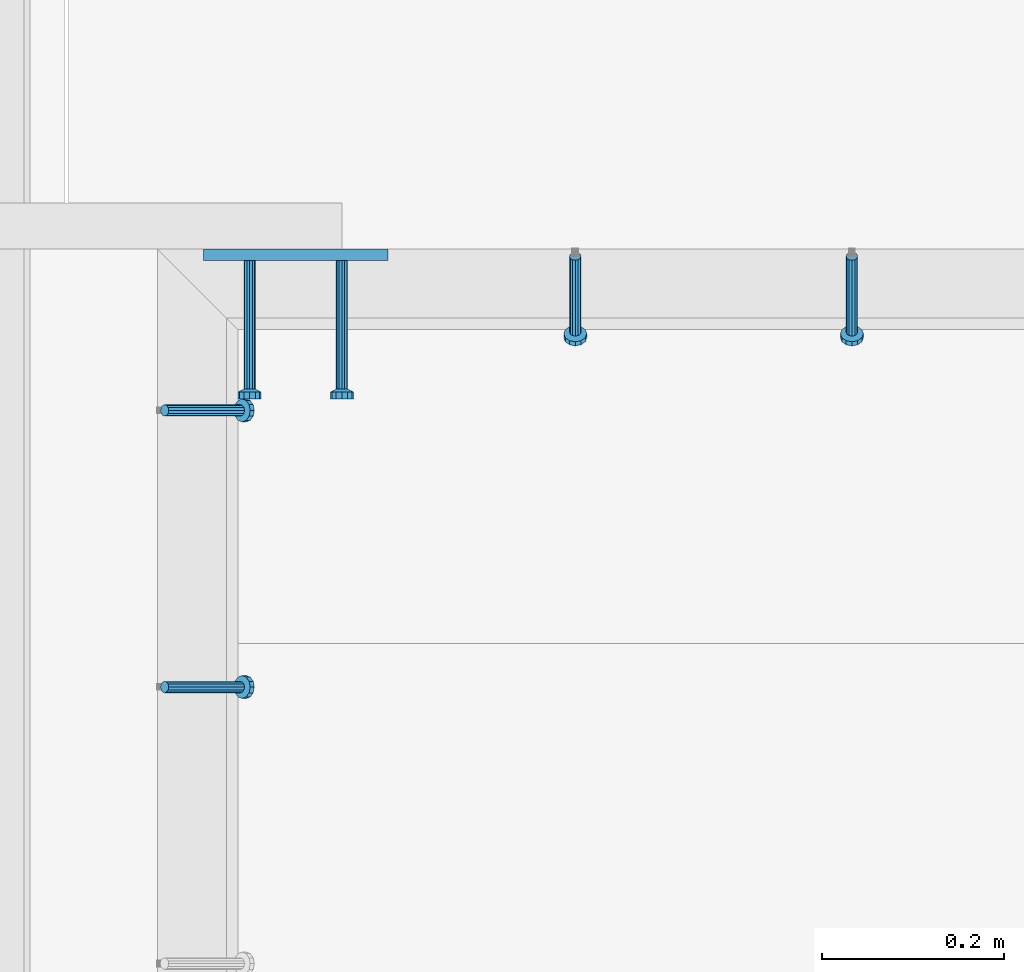
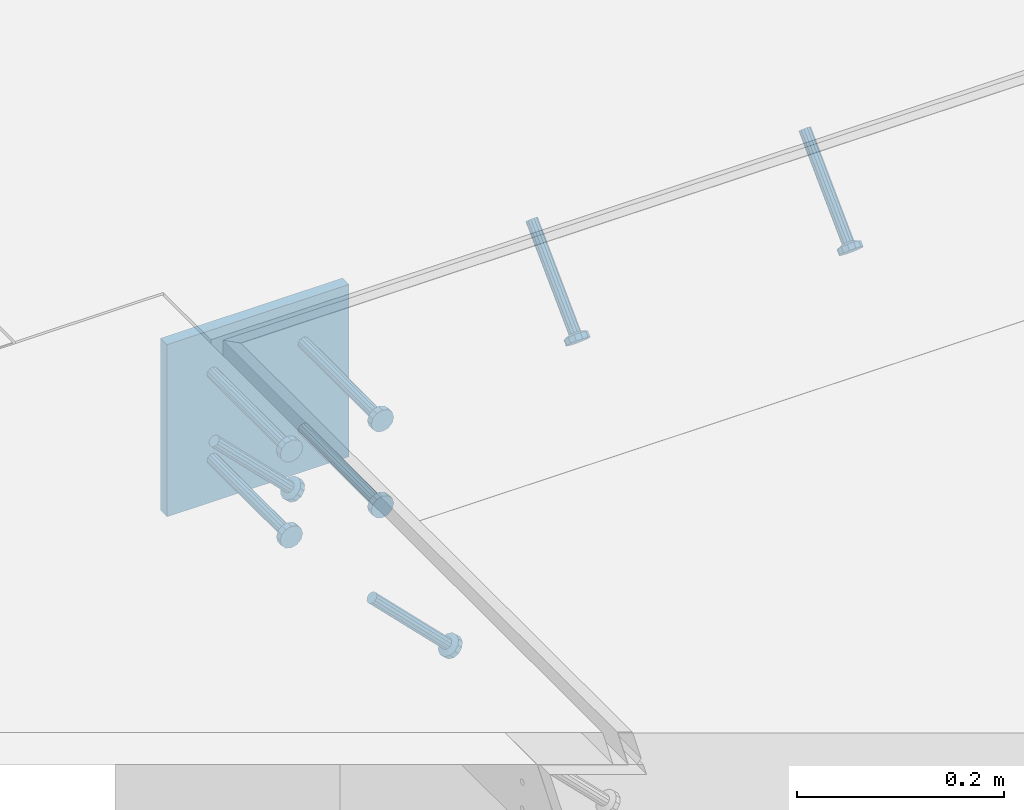
# One storey, part 2537 of 3843: 5 beams, 4 members, 3 elements without a shape of their own.
"""IFC2X3 building model written with IfcOpenShell, lengths in millimetres."""

from ifc_helpers import new_model, si_unit, frame, origin_with_axes, place, context, subcontext, project, spatial, faceted_brep, material, type_object, element, aggregate, save


model = new_model("IFC2X3")

# Units and contexts
model_context = context("Model", 3, precision=1e-05, world=origin_with_axes())
body_context = subcontext(model_context, "Body", "Model", "MODEL_VIEW")
ifc_project = project(units=[si_unit("LENGTHUNIT", "METRE", prefix="MILLI"), si_unit("AREAUNIT", "SQUARE_METRE"), si_unit("VOLUMEUNIT", "CUBIC_METRE"), si_unit("MASSUNIT", "GRAM", prefix="KILO"), si_unit("TIMEUNIT", "SECOND"), si_unit("PLANEANGLEUNIT", "RADIAN"), si_unit("SOLIDANGLEUNIT", "STERADIAN"), si_unit("THERMODYNAMICTEMPERATUREUNIT", "DEGREE_CELSIUS"), si_unit("LUMINOUSINTENSITYUNIT", "LUMEN")], contexts=[model_context])

# Site, building, storey
site_placement = place(None, origin_with_axes())
site = spatial("IfcSite", under=ifc_project, at=site_placement, CompositionType="ELEMENT")
building_placement = place(site_placement, origin_with_axes())
building = spatial("IfcBuilding", under=site, at=building_placement, Name="Undefined", CompositionType="ELEMENT")
storey_placement = place(building_placement, origin_with_axes())
storey = spatial("IfcBuildingStorey", under=building, at=storey_placement, Name="Undefined", CompositionType="ELEMENT", Elevation=0.0)

# Assembly, members
assembly_1_placement = place(storey_placement, origin_with_axes())
assembly_1 = element("IfcElementAssembly", 1, at=assembly_1_placement, inside=storey, Name="EMBED_ANGLE", AssemblyPlace="NOTDEFINED", PredefinedType="RIGID_FRAME")
ifc_material_1 = material(Name="STEEL/A108")
member_type = type_object("IfcMemberType", PredefinedType="NOTDEFINED")
member_1_placement = place(assembly_1_placement, frame((67434.600304105, 90041.2848828318, 30446.6625), z_axis=(-1.0, 0.0, 0.0), x_axis=(0.0, -0.707106781186548, -0.707106781186548)))
member_1 = element("IfcMember", 2, at=member_1_placement, type_object=member_type, material=ifc_material_1, Name="HEADED STUD ANCHOR", context=body_context, shape_type="Brep", body=[
    faceted_brep([(7.27595761418343e-12, -3.18000006675175, 5.5), (0.0, -5.49999999998363, 3.1800000667572), (118.110000000976, -5.49999999999091, 3.1800000667572), (118.110000000983, -3.18000006675175, 5.5), (0.0, -6.3499999046162, 0.0), (118.110000000968, -6.34999990461256, 0.0), (0.0, -5.49999999998363, -3.1800000667572), (118.110000000976, -5.49999999999091, -3.1800000667572), (7.27595761418343e-12, -3.18000006675175, -5.5), (118.110000000983, -3.18000006675175, -5.5), (7.27595761418343e-12, -1.81898940354586e-12, -6.34999990463257), (118.110000000968, -1.81898940354586e-12, -6.34999990463257), (0.0, 3.18000006675175, -5.5), (118.110000000968, 3.18000006674811, -5.5), (7.27595761418343e-12, 5.49999999998363, -3.1800000667572), (118.110000000983, 5.49999999998363, -3.1800000667572), (7.27595761418343e-12, 6.3499999046162, 0.0), (118.110000000976, 6.34999990461256, 0.0), (7.27595761418343e-12, 5.49999999998363, 3.1800000667572), (118.110000000983, 5.49999999998363, 3.1800000667572), (0.0, 3.18000006675175, 5.5), (118.110000000968, 3.18000006674811, 5.5), (7.27595761418343e-12, -1.81898940354586e-12, 6.34999990463257), (118.110000000968, -1.81898940354586e-12, 6.34999990463257), (120.650000000991, -10.9899997710909, 6.34999990463257), (120.650000000998, -6.34000015257152, 10.9899997711182), (120.650000000991, -12.6999998092379, 0.0), (120.650000000991, -10.9899997710909, -6.34999990463257), (120.650000000998, -6.34000015257152, -10.9899997711182), (120.650000000991, -1.81898940354586e-12, -12.6899995803833), (120.650000000991, 6.34000015257152, -10.9899997711182), (120.650000000998, 10.9899997710909, -6.34999990463257), (120.650000000991, 12.6999998092342, 0.0), (120.650000000998, 10.9899997710909, 6.34999990463257), (120.650000000991, 6.34000015257152, 10.9899997711182), (120.650000000991, -1.81898940354586e-12, 12.6899995803833), (127.000000001048, -10.9899997710945, 6.34999990463257), (127.000000001048, -6.34000015257152, 10.9899997711182), (127.000000001048, -12.6999998092342, 0.0), (127.000000001048, -10.9899997710945, -6.34999990463257), (127.000000001048, -6.34000015257152, -10.9899997711182), (127.000000001048, 1.81898940354586e-12, -12.6899995803833), (127.000000001048, 6.34000015256788, -10.9899997711182), (127.000000001048, 10.9899997710909, -6.34999990463257), (127.000000001048, 12.6999998092379, 0.0), (127.000000001048, 10.9899997710909, 6.34999990463257), (127.000000001048, 6.34000015256788, 10.9899997711182), (127.000000001048, 1.81898940354586e-12, 12.6899995803833)], [[[0, 1, 2, 3]], [[1, 4, 5, 2]], [[4, 6, 7, 5]], [[6, 8, 9, 7]], [[8, 10, 11, 9]], [[10, 12, 13, 11]], [[12, 14, 15, 13]], [[14, 16, 17, 15]], [[16, 18, 19, 17]], [[18, 20, 21, 19]], [[20, 22, 23, 21]], [[22, 0, 3, 23]], [[22, 20, 18, 16, 14, 12, 10, 8, 6, 4, 1, 0]], [[3, 2, 24, 25]], [[2, 5, 26, 24]], [[5, 7, 27, 26]], [[7, 9, 28, 27]], [[9, 11, 29, 28]], [[11, 13, 30, 29]], [[13, 15, 31, 30]], [[15, 17, 32, 31]], [[17, 19, 33, 32]], [[19, 21, 34, 33]], [[21, 23, 35, 34]], [[23, 3, 25, 35]], [[25, 24, 36, 37]], [[24, 26, 38, 36]], [[26, 27, 39, 38]], [[27, 28, 40, 39]], [[28, 29, 41, 40]], [[29, 30, 42, 41]], [[30, 31, 43, 42]], [[31, 32, 44, 43]], [[32, 33, 45, 44]], [[33, 34, 46, 45]], [[34, 35, 47, 46]], [[35, 25, 37, 47]], [[38, 39, 40, 41, 42, 43, 44, 45, 46, 47, 37, 36]]]),
])
member_2_placement = place(assembly_1_placement, frame((67129.800304105, 90041.2848828318, 30446.6625), z_axis=(-1.0, 0.0, 0.0), x_axis=(0.0, -0.707106781186548, -0.707106781186548)))
member_2 = element("IfcMember", 3, at=member_2_placement, type_object=member_type, material=ifc_material_1, Name="HEADED STUD ANCHOR", context=body_context, shape_type="Brep", body=[
    faceted_brep([(7.27595761418343e-12, -3.18000006675175, 5.5), (0.0, -5.49999999998363, 3.1800000667572), (118.110000000976, -5.49999999999091, 3.1800000667572), (118.110000000983, -3.18000006675175, 5.5), (0.0, -6.3499999046162, 0.0), (118.110000000968, -6.34999990461256, 0.0), (0.0, -5.49999999998363, -3.1800000667572), (118.110000000976, -5.49999999999091, -3.1800000667572), (7.27595761418343e-12, -3.18000006675175, -5.5), (118.110000000983, -3.18000006675175, -5.5), (7.27595761418343e-12, -1.81898940354586e-12, -6.34999990463257), (118.110000000968, -1.81898940354586e-12, -6.34999990463257), (0.0, 3.18000006675175, -5.5), (118.110000000968, 3.18000006674811, -5.5), (7.27595761418343e-12, 5.49999999998363, -3.1800000667572), (118.110000000983, 5.49999999998363, -3.1800000667572), (7.27595761418343e-12, 6.3499999046162, 0.0), (118.110000000976, 6.34999990461256, 0.0), (7.27595761418343e-12, 5.49999999998363, 3.1800000667572), (118.110000000983, 5.49999999998363, 3.1800000667572), (0.0, 3.18000006675175, 5.5), (118.110000000968, 3.18000006674811, 5.5), (7.27595761418343e-12, -1.81898940354586e-12, 6.34999990463257), (118.110000000968, -1.81898940354586e-12, 6.34999990463257), (120.650000000991, -10.9899997710909, 6.34999990463257), (120.650000000998, -6.34000015257152, 10.9899997711182), (120.650000000991, -12.6999998092379, 0.0), (120.650000000991, -10.9899997710909, -6.34999990463257), (120.650000000998, -6.34000015257152, -10.9899997711182), (120.650000000991, -1.81898940354586e-12, -12.6899995803833), (120.650000000991, 6.34000015257152, -10.9899997711182), (120.650000000998, 10.9899997710909, -6.34999990463257), (120.650000000991, 12.6999998092342, 0.0), (120.650000000998, 10.9899997710909, 6.34999990463257), (120.650000000991, 6.34000015257152, 10.9899997711182), (120.650000000991, -1.81898940354586e-12, 12.6899995803833), (127.000000001048, -10.9899997710945, 6.34999990463257), (127.000000001048, -6.34000015257152, 10.9899997711182), (127.000000001048, -12.6999998092342, 0.0), (127.000000001048, -10.9899997710945, -6.34999990463257), (127.000000001048, -6.34000015257152, -10.9899997711182), (127.000000001048, 1.81898940354586e-12, -12.6899995803833), (127.000000001048, 6.34000015256788, -10.9899997711182), (127.000000001048, 10.9899997710909, -6.34999990463257), (127.000000001048, 12.6999998092379, 0.0), (127.000000001048, 10.9899997710909, 6.34999990463257), (127.000000001048, 6.34000015256788, 10.9899997711182), (127.000000001048, 1.81898940354586e-12, 12.6899995803833)], [[[0, 1, 2, 3]], [[1, 4, 5, 2]], [[4, 6, 7, 5]], [[6, 8, 9, 7]], [[8, 10, 11, 9]], [[10, 12, 13, 11]], [[12, 14, 15, 13]], [[14, 16, 17, 15]], [[16, 18, 19, 17]], [[18, 20, 21, 19]], [[20, 22, 23, 21]], [[22, 0, 3, 23]], [[22, 20, 18, 16, 14, 12, 10, 8, 6, 4, 1, 0]], [[3, 2, 24, 25]], [[2, 5, 26, 24]], [[5, 7, 27, 26]], [[7, 9, 28, 27]], [[9, 11, 29, 28]], [[11, 13, 30, 29]], [[13, 15, 31, 30]], [[15, 17, 32, 31]], [[17, 19, 33, 32]], [[19, 21, 34, 33]], [[21, 23, 35, 34]], [[23, 3, 25, 35]], [[25, 24, 36, 37]], [[24, 26, 38, 36]], [[26, 27, 39, 38]], [[27, 28, 40, 39]], [[28, 29, 41, 40]], [[29, 30, 42, 41]], [[30, 31, 43, 42]], [[31, 32, 44, 43]], [[32, 33, 45, 44]], [[33, 34, 46, 45]], [[34, 35, 47, 46]], [[35, 25, 37, 47]], [[38, 39, 40, 41, 42, 43, 44, 45, 46, 47, 37, 36]]]),
])
aggregate(assembly_1, [member_1, member_2])

assembly_2_placement = place(storey_placement, origin_with_axes())
assembly_2 = element("IfcElementAssembly", 4, at=assembly_2_placement, inside=storey, Name="EMBED_ANGLE", AssemblyPlace="NOTDEFINED", PredefinedType="RIGID_FRAME")
member_3_placement = place(assembly_2_placement, frame((66677.3495, 89566.6227092285, 30446.6625), z_axis=(0.0, 1.0, 0.0), x_axis=(0.707106781186548, 0.0, -0.707106781186548)))
member_3 = element("IfcMember", 5, at=member_3_placement, type_object=member_type, material=ifc_material_1, Name="HEADED STUD ANCHOR", context=body_context, shape_type="Brep", body=[
    faceted_brep([(7.27595761418343e-12, -3.18000006675175, 5.5), (0.0, -5.49999999998363, 3.1800000667572), (118.110000000976, -5.49999999999091, 3.1800000667572), (118.110000000983, -3.18000006675175, 5.5), (0.0, -6.3499999046162, 0.0), (118.110000000968, -6.34999990461256, 0.0), (0.0, -5.49999999998363, -3.1800000667572), (118.110000000976, -5.49999999999091, -3.1800000667572), (7.27595761418343e-12, -3.18000006675175, -5.5), (118.110000000983, -3.18000006675175, -5.5), (7.27595761418343e-12, -1.81898940354586e-12, -6.34999990463257), (118.110000000968, -1.81898940354586e-12, -6.34999990463257), (0.0, 3.18000006675175, -5.5), (118.110000000968, 3.18000006674811, -5.5), (7.27595761418343e-12, 5.49999999998363, -3.1800000667572), (118.110000000983, 5.49999999998363, -3.1800000667572), (7.27595761418343e-12, 6.3499999046162, 0.0), (118.110000000976, 6.34999990461256, 0.0), (7.27595761418343e-12, 5.49999999998363, 3.1800000667572), (118.110000000983, 5.49999999998363, 3.1800000667572), (0.0, 3.18000006675175, 5.5), (118.110000000968, 3.18000006674811, 5.5), (7.27595761418343e-12, -1.81898940354586e-12, 6.34999990463257), (118.110000000968, -1.81898940354586e-12, 6.34999990463257), (120.650000000991, -10.9899997710909, 6.34999990463257), (120.650000000998, -6.34000015257152, 10.9899997711182), (120.650000000991, -12.6999998092379, 0.0), (120.650000000991, -10.9899997710909, -6.34999990463257), (120.650000000998, -6.34000015257152, -10.9899997711182), (120.650000000991, -1.81898940354586e-12, -12.6899995803833), (120.650000000991, 6.34000015257152, -10.9899997711182), (120.650000000998, 10.9899997710909, -6.34999990463257), (120.650000000991, 12.6999998092342, 0.0), (120.650000000998, 10.9899997710909, 6.34999990463257), (120.650000000991, 6.34000015257152, 10.9899997711182), (120.650000000991, -1.81898940354586e-12, 12.6899995803833), (127.000000001048, -10.9899997710945, 6.34999990463257), (127.000000001048, -6.34000015257152, 10.9899997711182), (127.000000001048, -12.6999998092342, 0.0), (127.000000001048, -10.9899997710945, -6.34999990463257), (127.000000001048, -6.34000015257152, -10.9899997711182), (127.000000001048, 1.81898940354586e-12, -12.6899995803833), (127.000000001048, 6.34000015256788, -10.9899997711182), (127.000000001048, 10.9899997710909, -6.34999990463257), (127.000000001048, 12.6999998092379, 0.0), (127.000000001048, 10.9899997710909, 6.34999990463257), (127.000000001048, 6.34000015256788, 10.9899997711182), (127.000000001048, 1.81898940354586e-12, 12.6899995803833)], [[[0, 1, 2, 3]], [[1, 4, 5, 2]], [[4, 6, 7, 5]], [[6, 8, 9, 7]], [[8, 10, 11, 9]], [[10, 12, 13, 11]], [[12, 14, 15, 13]], [[14, 16, 17, 15]], [[16, 18, 19, 17]], [[18, 20, 21, 19]], [[20, 22, 23, 21]], [[22, 0, 3, 23]], [[22, 20, 18, 16, 14, 12, 10, 8, 6, 4, 1, 0]], [[3, 2, 24, 25]], [[2, 5, 26, 24]], [[5, 7, 27, 26]], [[7, 9, 28, 27]], [[9, 11, 29, 28]], [[11, 13, 30, 29]], [[13, 15, 31, 30]], [[15, 17, 32, 31]], [[17, 19, 33, 32]], [[19, 21, 34, 33]], [[21, 23, 35, 34]], [[23, 3, 25, 35]], [[25, 24, 36, 37]], [[24, 26, 38, 36]], [[26, 27, 39, 38]], [[27, 28, 40, 39]], [[28, 29, 41, 40]], [[29, 30, 42, 41]], [[30, 31, 43, 42]], [[31, 32, 44, 43]], [[32, 33, 45, 44]], [[33, 34, 46, 45]], [[34, 35, 47, 46]], [[35, 25, 37, 47]], [[38, 39, 40, 41, 42, 43, 44, 45, 46, 47, 37, 36]]]),
])
member_4_placement = place(assembly_2_placement, frame((66677.3495, 89871.4227092285, 30446.6625), z_axis=(0.0, 1.0, 0.0), x_axis=(0.707106781186548, 0.0, -0.707106781186548)))
member_4 = element("IfcMember", 6, at=member_4_placement, type_object=member_type, material=ifc_material_1, Name="HEADED STUD ANCHOR", context=body_context, shape_type="Brep", body=[
    faceted_brep([(7.27595761418343e-12, -3.18000006675175, 5.5), (0.0, -5.49999999998363, 3.1800000667572), (118.110000000976, -5.49999999999091, 3.1800000667572), (118.110000000983, -3.18000006675175, 5.5), (0.0, -6.3499999046162, 0.0), (118.110000000968, -6.34999990461256, 0.0), (0.0, -5.49999999998363, -3.1800000667572), (118.110000000976, -5.49999999999091, -3.1800000667572), (7.27595761418343e-12, -3.18000006675175, -5.5), (118.110000000983, -3.18000006675175, -5.5), (7.27595761418343e-12, -1.81898940354586e-12, -6.34999990463257), (118.110000000968, -1.81898940354586e-12, -6.34999990463257), (0.0, 3.18000006675175, -5.5), (118.110000000968, 3.18000006674811, -5.5), (7.27595761418343e-12, 5.49999999998363, -3.1800000667572), (118.110000000983, 5.49999999998363, -3.1800000667572), (7.27595761418343e-12, 6.3499999046162, 0.0), (118.110000000976, 6.34999990461256, 0.0), (7.27595761418343e-12, 5.49999999998363, 3.1800000667572), (118.110000000983, 5.49999999998363, 3.1800000667572), (0.0, 3.18000006675175, 5.5), (118.110000000968, 3.18000006674811, 5.5), (7.27595761418343e-12, -1.81898940354586e-12, 6.34999990463257), (118.110000000968, -1.81898940354586e-12, 6.34999990463257), (120.650000000991, -10.9899997710909, 6.34999990463257), (120.650000000998, -6.34000015257152, 10.9899997711182), (120.650000000991, -12.6999998092379, 0.0), (120.650000000991, -10.9899997710909, -6.34999990463257), (120.650000000998, -6.34000015257152, -10.9899997711182), (120.650000000991, -1.81898940354586e-12, -12.6899995803833), (120.650000000991, 6.34000015257152, -10.9899997711182), (120.650000000998, 10.9899997710909, -6.34999990463257), (120.650000000991, 12.6999998092342, 0.0), (120.650000000998, 10.9899997710909, 6.34999990463257), (120.650000000991, 6.34000015257152, 10.9899997711182), (120.650000000991, -1.81898940354586e-12, 12.6899995803833), (127.000000001048, -10.9899997710945, 6.34999990463257), (127.000000001048, -6.34000015257152, 10.9899997711182), (127.000000001048, -12.6999998092342, 0.0), (127.000000001048, -10.9899997710945, -6.34999990463257), (127.000000001048, -6.34000015257152, -10.9899997711182), (127.000000001048, 1.81898940354586e-12, -12.6899995803833), (127.000000001048, 6.34000015256788, -10.9899997711182), (127.000000001048, 10.9899997710909, -6.34999990463257), (127.000000001048, 12.6999998092379, 0.0), (127.000000001048, 10.9899997710909, 6.34999990463257), (127.000000001048, 6.34000015256788, 10.9899997711182), (127.000000001048, 1.81898940354586e-12, 12.6899995803833)], [[[0, 1, 2, 3]], [[1, 4, 5, 2]], [[4, 6, 7, 5]], [[6, 8, 9, 7]], [[8, 10, 11, 9]], [[10, 12, 13, 11]], [[12, 14, 15, 13]], [[14, 16, 17, 15]], [[16, 18, 19, 17]], [[18, 20, 21, 19]], [[20, 22, 23, 21]], [[22, 0, 3, 23]], [[22, 20, 18, 16, 14, 12, 10, 8, 6, 4, 1, 0]], [[3, 2, 24, 25]], [[2, 5, 26, 24]], [[5, 7, 27, 26]], [[7, 9, 28, 27]], [[9, 11, 29, 28]], [[11, 13, 30, 29]], [[13, 15, 31, 30]], [[15, 17, 32, 31]], [[17, 19, 33, 32]], [[19, 21, 34, 33]], [[21, 23, 35, 34]], [[23, 3, 25, 35]], [[25, 24, 36, 37]], [[24, 26, 38, 36]], [[26, 27, 39, 38]], [[27, 28, 40, 39]], [[28, 29, 41, 40]], [[29, 30, 42, 41]], [[30, 31, 43, 42]], [[31, 32, 44, 43]], [[32, 33, 45, 44]], [[33, 34, 46, 45]], [[34, 35, 47, 46]], [[35, 25, 37, 47]], [[38, 39, 40, 41, 42, 43, 44, 45, 46, 47, 37, 36]]]),
])
aggregate(assembly_2, [member_3, member_4])

# Assembly, beams
assembly_3_placement = place(storey_placement, origin_with_axes())
assembly_3 = element("IfcElementAssembly", 7, at=assembly_3_placement, inside=storey, Name="EMBED PLATE", AssemblyPlace="NOTDEFINED", PredefinedType="RIGID_FRAME")
ifc_material_2 = material(Name="STEEL/A36")
beam_type_1 = type_object("IfcBeamType", PredefinedType="NOTDEFINED")
beam_1_placement = place(assembly_3_placement, frame((66821.8119999943, 90042.8723828318, 30445.075), z_axis=(-1.0, 0.0, 0.0), x_axis=(0.0, 0.0, -1.0)))
beam_1 = element("IfcBeam", 8, at=beam_1_placement, type_object=beam_type_1, material=ifc_material_2, Name="EMBED PLATE", context=body_context, shape_type="Brep", body=[
    faceted_brep([(1.74622982740402e-10, 6.35000000000582, -101.600000000195), (-1.67347025126219e-10, 6.35000000000582, 101.600000000151), (203.200000000001, 6.35000000000582, 101.599999999999), (203.200000000001, 6.35000000000582, -101.599999999999), (-1.67347025126219e-10, -6.35000000000582, 101.600000000151), (203.200000000001, -6.35000000000582, 101.599999999999), (1.74622982740402e-10, -6.35000000000582, -101.600000000195), (203.200000000001, -6.35000000000582, -101.599999999999)], [[[0, 1, 2, 3]], [[1, 4, 5, 2]], [[4, 6, 7, 5]], [[6, 0, 3, 7]], [[5, 7, 3, 2]], [[6, 4, 1, 0]]]),
])
beam_type_2 = type_object("IfcBeamType", PredefinedType="NOTDEFINED")
beam_2_placement = place(assembly_3_placement, frame((66872.6119999943, 90036.5223828318, 30394.275), z_axis=(1.0, 0.0, 0.0), x_axis=(0.0, -1.0, 0.0)))
beam_2 = element("IfcBeam", 9, at=beam_2_placement, type_object=beam_type_2, material=ifc_material_1, Name="HEADED STUD ANCHOR", context=body_context, shape_type="Brep", body=[
    faceted_brep([(7.27595761418343e-12, -3.18000006675175, 5.5), (0.0, -5.49999999998363, 3.1800000667572), (141.731999999989, -5.5, 3.1800000667572), (141.731999999989, -3.1800000667572, 5.5), (0.0, -6.3499999046162, 0.0), (141.731999999989, -6.34999990463257, 0.0), (0.0, -5.49999999998363, -3.1800000667572), (141.731999999989, -5.5, -3.1800000667572), (7.27595761418343e-12, -3.18000006675175, -5.5), (141.731999999989, -3.1800000667572, -5.5), (7.27595761418343e-12, -1.81898940354586e-12, -6.34999990463257), (141.731999999989, 0.0, -6.34999990463257), (0.0, 3.18000006675175, -5.5), (141.731999999989, 3.1800000667572, -5.5), (7.27595761418343e-12, 5.49999999998363, -3.1800000667572), (141.731999999989, 5.5, -3.1800000667572), (7.27595761418343e-12, 6.3499999046162, 0.0), (141.731999999989, 6.34999990463257, 0.0), (7.27595761418343e-12, 5.49999999998363, 3.1800000667572), (141.731999999989, 5.5, 3.1800000667572), (0.0, 3.18000006675175, 5.5), (141.731999999989, 3.1800000667572, 5.5), (7.27595761418343e-12, -1.81898940354586e-12, 6.34999990463257), (141.731999999989, 0.0, 6.34999990463257), (144.779999999999, -10.9899997711182, 6.34999990463257), (144.779999999999, -6.34000015258789, 10.9899997711182), (144.779999999999, -12.6999998092651, 0.0), (144.779999999999, -10.9899997711182, -6.34999990463257), (144.779999999999, -6.34000015258789, -10.9899997711182), (144.779999999999, 0.0, -12.6899995803833), (144.779999999999, 6.34000015258789, -10.9899997711182), (144.779999999999, 10.9899997711182, -6.34999990463257), (144.779999999999, 12.6999998092651, 0.0), (144.779999999999, 10.9899997711182, 6.34999990463257), (144.779999999999, 6.34000015258789, 10.9899997711182), (144.779999999999, 0.0, 12.6899995803833), (152.399999999994, -10.9899997711182, 6.34999990463257), (152.399999999994, -6.34000015258789, 10.9899997711182), (152.399999999994, -12.6999998092651, 0.0), (152.399999999994, -10.9899997711182, -6.34999990463257), (152.399999999994, -6.34000015258789, -10.9899997711182), (152.399999999994, 0.0, -12.6899995803833), (152.399999999994, 6.34000015258789, -10.9899997711182), (152.399999999994, 10.9899997711182, -6.34999990463257), (152.399999999994, 12.6999998092651, 0.0), (152.399999999994, 10.9899997711182, 6.34999990463257), (152.399999999994, 6.34000015258789, 10.9899997711182), (152.399999999994, 0.0, 12.6899995803833)], [[[0, 1, 2, 3]], [[1, 4, 5, 2]], [[4, 6, 7, 5]], [[6, 8, 9, 7]], [[8, 10, 11, 9]], [[10, 12, 13, 11]], [[12, 14, 15, 13]], [[14, 16, 17, 15]], [[16, 18, 19, 17]], [[18, 20, 21, 19]], [[20, 22, 23, 21]], [[22, 0, 3, 23]], [[22, 20, 18, 16, 14, 12, 10, 8, 6, 4, 1, 0]], [[3, 2, 24, 25]], [[2, 5, 26, 24]], [[5, 7, 27, 26]], [[7, 9, 28, 27]], [[9, 11, 29, 28]], [[11, 13, 30, 29]], [[13, 15, 31, 30]], [[15, 17, 32, 31]], [[17, 19, 33, 32]], [[19, 21, 34, 33]], [[21, 23, 35, 34]], [[23, 3, 25, 35]], [[25, 24, 36, 37]], [[24, 26, 38, 36]], [[26, 27, 39, 38]], [[27, 28, 40, 39]], [[28, 29, 41, 40]], [[29, 30, 42, 41]], [[30, 31, 43, 42]], [[31, 32, 44, 43]], [[32, 33, 45, 44]], [[33, 34, 46, 45]], [[34, 35, 47, 46]], [[35, 25, 37, 47]], [[38, 39, 40, 41, 42, 43, 44, 45, 46, 47, 37, 36]]]),
])
beam_3_placement = place(assembly_3_placement, frame((66872.6119999943, 90036.5223828318, 30292.675), z_axis=(1.0, 0.0, 0.0), x_axis=(0.0, -1.0, 0.0)))
beam_3 = element("IfcBeam", 10, at=beam_3_placement, type_object=beam_type_2, material=ifc_material_1, Name="HEADED STUD ANCHOR", context=body_context, shape_type="Brep", body=[
    faceted_brep([(7.27595761418343e-12, -3.18000006675175, 5.5), (0.0, -5.49999999998363, 3.1800000667572), (141.731999999989, -5.5, 3.1800000667572), (141.731999999989, -3.1800000667572, 5.5), (0.0, -6.3499999046162, 0.0), (141.731999999989, -6.34999990463257, 0.0), (0.0, -5.49999999998363, -3.1800000667572), (141.731999999989, -5.5, -3.1800000667572), (7.27595761418343e-12, -3.18000006675175, -5.5), (141.731999999989, -3.1800000667572, -5.5), (7.27595761418343e-12, -1.81898940354586e-12, -6.34999990463257), (141.731999999989, 0.0, -6.34999990463257), (0.0, 3.18000006675175, -5.5), (141.731999999989, 3.1800000667572, -5.5), (7.27595761418343e-12, 5.49999999998363, -3.1800000667572), (141.731999999989, 5.5, -3.1800000667572), (7.27595761418343e-12, 6.3499999046162, 0.0), (141.731999999989, 6.34999990463257, 0.0), (7.27595761418343e-12, 5.49999999998363, 3.1800000667572), (141.731999999989, 5.5, 3.1800000667572), (0.0, 3.18000006675175, 5.5), (141.731999999989, 3.1800000667572, 5.5), (7.27595761418343e-12, -1.81898940354586e-12, 6.34999990463257), (141.731999999989, 0.0, 6.34999990463257), (144.779999999999, -10.9899997711182, 6.34999990463257), (144.779999999999, -6.34000015258789, 10.9899997711182), (144.779999999999, -12.6999998092651, 0.0), (144.779999999999, -10.9899997711182, -6.34999990463257), (144.779999999999, -6.34000015258789, -10.9899997711182), (144.779999999999, 0.0, -12.6899995803833), (144.779999999999, 6.34000015258789, -10.9899997711182), (144.779999999999, 10.9899997711182, -6.34999990463257), (144.779999999999, 12.6999998092651, 0.0), (144.779999999999, 10.9899997711182, 6.34999990463257), (144.779999999999, 6.34000015258789, 10.9899997711182), (144.779999999999, 0.0, 12.6899995803833), (152.399999999994, -10.9899997711182, 6.34999990463257), (152.399999999994, -6.34000015258789, 10.9899997711182), (152.399999999994, -12.6999998092651, 0.0), (152.399999999994, -10.9899997711182, -6.34999990463257), (152.399999999994, -6.34000015258789, -10.9899997711182), (152.399999999994, 0.0, -12.6899995803833), (152.399999999994, 6.34000015258789, -10.9899997711182), (152.399999999994, 10.9899997711182, -6.34999990463257), (152.399999999994, 12.6999998092651, 0.0), (152.399999999994, 10.9899997711182, 6.34999990463257), (152.399999999994, 6.34000015258789, 10.9899997711182), (152.399999999994, 0.0, 12.6899995803833)], [[[0, 1, 2, 3]], [[1, 4, 5, 2]], [[4, 6, 7, 5]], [[6, 8, 9, 7]], [[8, 10, 11, 9]], [[10, 12, 13, 11]], [[12, 14, 15, 13]], [[14, 16, 17, 15]], [[16, 18, 19, 17]], [[18, 20, 21, 19]], [[20, 22, 23, 21]], [[22, 0, 3, 23]], [[22, 20, 18, 16, 14, 12, 10, 8, 6, 4, 1, 0]], [[3, 2, 24, 25]], [[2, 5, 26, 24]], [[5, 7, 27, 26]], [[7, 9, 28, 27]], [[9, 11, 29, 28]], [[11, 13, 30, 29]], [[13, 15, 31, 30]], [[15, 17, 32, 31]], [[17, 19, 33, 32]], [[19, 21, 34, 33]], [[21, 23, 35, 34]], [[23, 3, 25, 35]], [[25, 24, 36, 37]], [[24, 26, 38, 36]], [[26, 27, 39, 38]], [[27, 28, 40, 39]], [[28, 29, 41, 40]], [[29, 30, 42, 41]], [[30, 31, 43, 42]], [[31, 32, 44, 43]], [[32, 33, 45, 44]], [[33, 34, 46, 45]], [[34, 35, 47, 46]], [[35, 25, 37, 47]], [[38, 39, 40, 41, 42, 43, 44, 45, 46, 47, 37, 36]]]),
])
beam_4_placement = place(assembly_3_placement, frame((66771.0119999943, 90036.5223828318, 30394.275), z_axis=(1.0, 0.0, 0.0), x_axis=(0.0, -1.0, 0.0)))
beam_4 = element("IfcBeam", 11, at=beam_4_placement, type_object=beam_type_2, material=ifc_material_1, Name="HEADED STUD ANCHOR", context=body_context, shape_type="Brep", body=[
    faceted_brep([(7.27595761418343e-12, -3.18000006675175, 5.5), (0.0, -5.49999999998363, 3.1800000667572), (141.731999999989, -5.5, 3.1800000667572), (141.731999999989, -3.1800000667572, 5.5), (0.0, -6.3499999046162, 0.0), (141.731999999989, -6.34999990463257, 0.0), (0.0, -5.49999999998363, -3.1800000667572), (141.731999999989, -5.5, -3.1800000667572), (7.27595761418343e-12, -3.18000006675175, -5.5), (141.731999999989, -3.1800000667572, -5.5), (7.27595761418343e-12, -1.81898940354586e-12, -6.34999990463257), (141.731999999989, 0.0, -6.34999990463257), (0.0, 3.18000006675175, -5.5), (141.731999999989, 3.1800000667572, -5.5), (7.27595761418343e-12, 5.49999999998363, -3.1800000667572), (141.731999999989, 5.5, -3.1800000667572), (7.27595761418343e-12, 6.3499999046162, 0.0), (141.731999999989, 6.34999990463257, 0.0), (7.27595761418343e-12, 5.49999999998363, 3.1800000667572), (141.731999999989, 5.5, 3.1800000667572), (0.0, 3.18000006675175, 5.5), (141.731999999989, 3.1800000667572, 5.5), (7.27595761418343e-12, -1.81898940354586e-12, 6.34999990463257), (141.731999999989, 0.0, 6.34999990463257), (144.779999999999, -10.9899997711182, 6.34999990463257), (144.779999999999, -6.34000015258789, 10.9899997711182), (144.779999999999, -12.6999998092651, 0.0), (144.779999999999, -10.9899997711182, -6.34999990463257), (144.779999999999, -6.34000015258789, -10.9899997711182), (144.779999999999, 0.0, -12.6899995803833), (144.779999999999, 6.34000015258789, -10.9899997711182), (144.779999999999, 10.9899997711182, -6.34999990463257), (144.779999999999, 12.6999998092651, 0.0), (144.779999999999, 10.9899997711182, 6.34999990463257), (144.779999999999, 6.34000015258789, 10.9899997711182), (144.779999999999, 0.0, 12.6899995803833), (152.399999999994, -10.9899997711182, 6.34999990463257), (152.399999999994, -6.34000015258789, 10.9899997711182), (152.399999999994, -12.6999998092651, 0.0), (152.399999999994, -10.9899997711182, -6.34999990463257), (152.399999999994, -6.34000015258789, -10.9899997711182), (152.399999999994, 0.0, -12.6899995803833), (152.399999999994, 6.34000015258789, -10.9899997711182), (152.399999999994, 10.9899997711182, -6.34999990463257), (152.399999999994, 12.6999998092651, 0.0), (152.399999999994, 10.9899997711182, 6.34999990463257), (152.399999999994, 6.34000015258789, 10.9899997711182), (152.399999999994, 0.0, 12.6899995803833)], [[[0, 1, 2, 3]], [[1, 4, 5, 2]], [[4, 6, 7, 5]], [[6, 8, 9, 7]], [[8, 10, 11, 9]], [[10, 12, 13, 11]], [[12, 14, 15, 13]], [[14, 16, 17, 15]], [[16, 18, 19, 17]], [[18, 20, 21, 19]], [[20, 22, 23, 21]], [[22, 0, 3, 23]], [[22, 20, 18, 16, 14, 12, 10, 8, 6, 4, 1, 0]], [[3, 2, 24, 25]], [[2, 5, 26, 24]], [[5, 7, 27, 26]], [[7, 9, 28, 27]], [[9, 11, 29, 28]], [[11, 13, 30, 29]], [[13, 15, 31, 30]], [[15, 17, 32, 31]], [[17, 19, 33, 32]], [[19, 21, 34, 33]], [[21, 23, 35, 34]], [[23, 3, 25, 35]], [[25, 24, 36, 37]], [[24, 26, 38, 36]], [[26, 27, 39, 38]], [[27, 28, 40, 39]], [[28, 29, 41, 40]], [[29, 30, 42, 41]], [[30, 31, 43, 42]], [[31, 32, 44, 43]], [[32, 33, 45, 44]], [[33, 34, 46, 45]], [[34, 35, 47, 46]], [[35, 25, 37, 47]], [[38, 39, 40, 41, 42, 43, 44, 45, 46, 47, 37, 36]]]),
])
beam_5_placement = place(assembly_3_placement, frame((66771.0119999943, 90036.5223828318, 30292.675), z_axis=(1.0, 0.0, 0.0), x_axis=(0.0, -1.0, 0.0)))
beam_5 = element("IfcBeam", 12, at=beam_5_placement, type_object=beam_type_2, material=ifc_material_1, Name="HEADED STUD ANCHOR", context=body_context, shape_type="Brep", body=[
    faceted_brep([(7.27595761418343e-12, -3.18000006675175, 5.5), (0.0, -5.49999999998363, 3.1800000667572), (141.731999999989, -5.5, 3.1800000667572), (141.731999999989, -3.1800000667572, 5.5), (0.0, -6.3499999046162, 0.0), (141.731999999989, -6.34999990463257, 0.0), (0.0, -5.49999999998363, -3.1800000667572), (141.731999999989, -5.5, -3.1800000667572), (7.27595761418343e-12, -3.18000006675175, -5.5), (141.731999999989, -3.1800000667572, -5.5), (7.27595761418343e-12, -1.81898940354586e-12, -6.34999990463257), (141.731999999989, 0.0, -6.34999990463257), (0.0, 3.18000006675175, -5.5), (141.731999999989, 3.1800000667572, -5.5), (7.27595761418343e-12, 5.49999999998363, -3.1800000667572), (141.731999999989, 5.5, -3.1800000667572), (7.27595761418343e-12, 6.3499999046162, 0.0), (141.731999999989, 6.34999990463257, 0.0), (7.27595761418343e-12, 5.49999999998363, 3.1800000667572), (141.731999999989, 5.5, 3.1800000667572), (0.0, 3.18000006675175, 5.5), (141.731999999989, 3.1800000667572, 5.5), (7.27595761418343e-12, -1.81898940354586e-12, 6.34999990463257), (141.731999999989, 0.0, 6.34999990463257), (144.779999999999, -10.9899997711182, 6.34999990463257), (144.779999999999, -6.34000015258789, 10.9899997711182), (144.779999999999, -12.6999998092651, 0.0), (144.779999999999, -10.9899997711182, -6.34999990463257), (144.779999999999, -6.34000015258789, -10.9899997711182), (144.779999999999, 0.0, -12.6899995803833), (144.779999999999, 6.34000015258789, -10.9899997711182), (144.779999999999, 10.9899997711182, -6.34999990463257), (144.779999999999, 12.6999998092651, 0.0), (144.779999999999, 10.9899997711182, 6.34999990463257), (144.779999999999, 6.34000015258789, 10.9899997711182), (144.779999999999, 0.0, 12.6899995803833), (152.399999999994, -10.9899997711182, 6.34999990463257), (152.399999999994, -6.34000015258789, 10.9899997711182), (152.399999999994, -12.6999998092651, 0.0), (152.399999999994, -10.9899997711182, -6.34999990463257), (152.399999999994, -6.34000015258789, -10.9899997711182), (152.399999999994, 0.0, -12.6899995803833), (152.399999999994, 6.34000015258789, -10.9899997711182), (152.399999999994, 10.9899997711182, -6.34999990463257), (152.399999999994, 12.6999998092651, 0.0), (152.399999999994, 10.9899997711182, 6.34999990463257), (152.399999999994, 6.34000015258789, 10.9899997711182), (152.399999999994, 0.0, 12.6899995803833)], [[[0, 1, 2, 3]], [[1, 4, 5, 2]], [[4, 6, 7, 5]], [[6, 8, 9, 7]], [[8, 10, 11, 9]], [[10, 12, 13, 11]], [[12, 14, 15, 13]], [[14, 16, 17, 15]], [[16, 18, 19, 17]], [[18, 20, 21, 19]], [[20, 22, 23, 21]], [[22, 0, 3, 23]], [[22, 20, 18, 16, 14, 12, 10, 8, 6, 4, 1, 0]], [[3, 2, 24, 25]], [[2, 5, 26, 24]], [[5, 7, 27, 26]], [[7, 9, 28, 27]], [[9, 11, 29, 28]], [[11, 13, 30, 29]], [[13, 15, 31, 30]], [[15, 17, 32, 31]], [[17, 19, 33, 32]], [[19, 21, 34, 33]], [[21, 23, 35, 34]], [[23, 3, 25, 35]], [[25, 24, 36, 37]], [[24, 26, 38, 36]], [[26, 27, 39, 38]], [[27, 28, 40, 39]], [[28, 29, 41, 40]], [[29, 30, 42, 41]], [[30, 31, 43, 42]], [[31, 32, 44, 43]], [[32, 33, 45, 44]], [[33, 34, 46, 45]], [[34, 35, 47, 46]], [[35, 25, 37, 47]], [[38, 39, 40, 41, 42, 43, 44, 45, 46, 47, 37, 36]]]),
])
aggregate(assembly_3, [beam_2, beam_3, beam_4, beam_5, beam_1])

save(model, "model.ifc")
